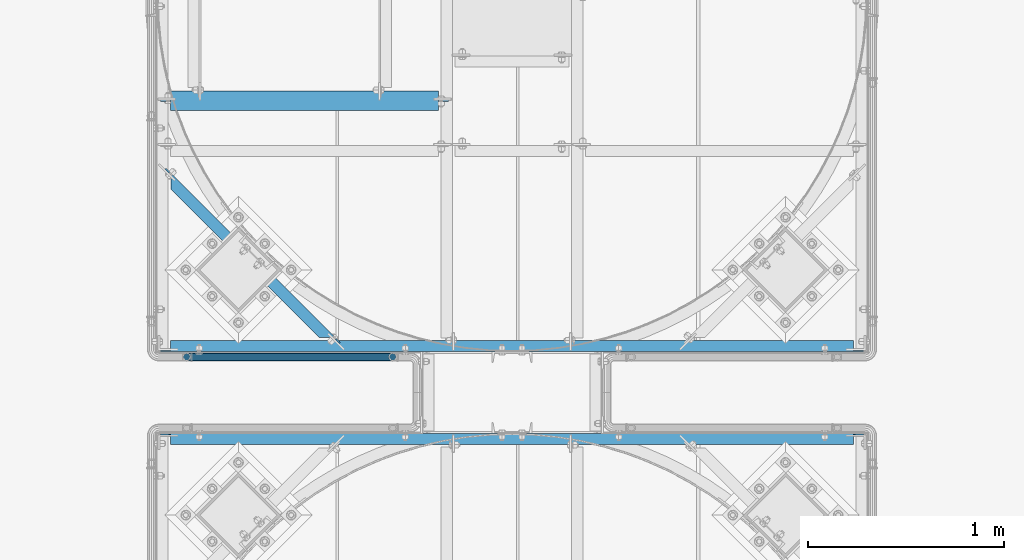
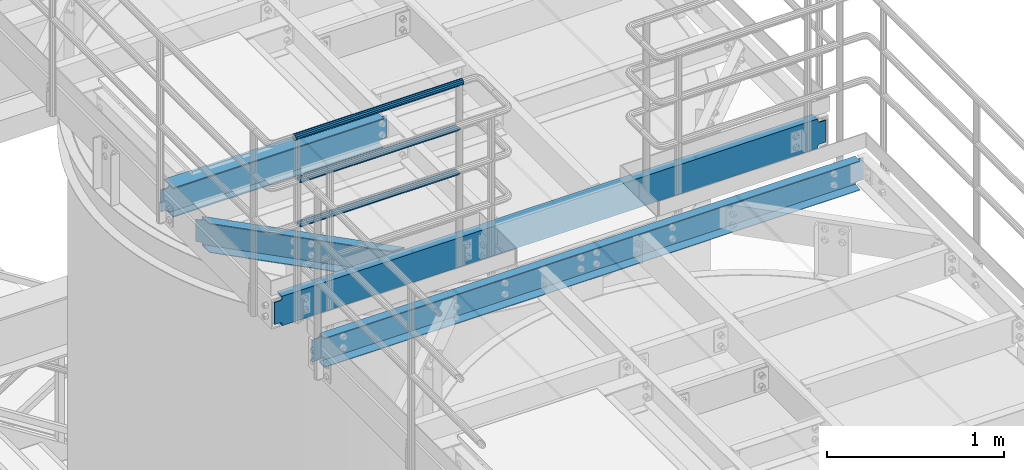
# One storey, part 926 of 1876: 7 beams, 5 elements without a shape of their own.
"""IFC2X3 building model written with IfcOpenShell, lengths in millimetres."""

from ifc_helpers import new_model, si_unit, frame, origin_with_axes, place, context, subcontext, project, spatial, faceted_brep, material, type_object, element, aggregate, save


model = new_model("IFC2X3")

# Units and contexts
model_context = context("Model", 3, precision=1e-05, world=origin_with_axes())
body_context = subcontext(model_context, "Body", "Model", "MODEL_VIEW")
ifc_project = project(units=[si_unit("LENGTHUNIT", "METRE", prefix="MILLI"), si_unit("AREAUNIT", "SQUARE_METRE"), si_unit("VOLUMEUNIT", "CUBIC_METRE"), si_unit("MASSUNIT", "GRAM", prefix="KILO"), si_unit("TIMEUNIT", "SECOND"), si_unit("PLANEANGLEUNIT", "RADIAN"), si_unit("SOLIDANGLEUNIT", "STERADIAN"), si_unit("THERMODYNAMICTEMPERATUREUNIT", "DEGREE_CELSIUS"), si_unit("LUMINOUSINTENSITYUNIT", "LUMEN")], contexts=[model_context])

# Site, building, storey
site_placement = place(None, origin_with_axes())
site = spatial("IfcSite", under=ifc_project, at=site_placement, CompositionType="ELEMENT")
building_placement = place(site_placement, origin_with_axes())
building = spatial("IfcBuilding", under=site, at=building_placement, Name="Undefined", CompositionType="ELEMENT")
storey_placement = place(building_placement, origin_with_axes())
storey = spatial("IfcBuildingStorey", under=building, at=storey_placement, Name="Undefined", CompositionType="ELEMENT", Elevation=0.0)

# Assembly, beams
assembly_1_placement = place(storey_placement, origin_with_axes())
assembly_1 = element("IfcElementAssembly", 1, at=assembly_1_placement, inside=storey, Name="HANDRAIL", AssemblyPlace="NOTDEFINED", PredefinedType="RIGID_FRAME")
ifc_material_1 = material()
beam_type_1 = type_object("IfcBeamType", Name="PIPE1-1/4STD", PredefinedType="NOTDEFINED")
beam_1_placement = place(assembly_1_placement, frame((4572.00474593762, -11381.1963554687, 8480.425), z_axis=(0.0, 0.0, 1.0), x_axis=(-1.0, 0.0, 0.0)))
beam_1 = element("IfcBeam", 2, at=beam_1_placement, type_object=beam_type_1, material=ifc_material_1, Name="RAIL", ObjectType="PIPE1-1/4STD", context=body_context, shape_type="Brep", body=[
    faceted_brep([(1035.84245243742, -10.5409999999993, 18.2575475625836), (1035.84245243742, -10.5409999999993, 13.3999612267253), (1035.36603877327, -8.76300000000083, 15.1779612267255), (1033.018, 0.0, 17.5259999999998), (1033.018, 0.0, 21.0820000000003), (1035.36603877327, 8.76300000000083, 15.1779612267255), (1035.84245243742, 10.5409999999993, 13.3999612267253), (1035.84245243742, 10.5409999999993, 18.2575475625836), (1054.1, 21.0820000000003, 0.0), (1043.559, 18.2575475625836, 10.5409999999993), (1043.559, 18.2575475625836, -10.5409999999993), (1040.47941366414, 15.1779612267255, 8.76300000000083), (1042.82745243742, 17.5259999999998, 0.0), (1040.47941366414, 15.1779612267255, -8.76300000000083), (1035.84245243742, 10.5409999999993, -13.3999612267253), (1035.84245243742, 10.5409999999993, -18.2575475625836), (1035.36603877327, 8.76300000000083, -15.1779612267255), (1033.018, 0.0, -17.5259999999998), (1033.018, 0.0, -21.0820000000003), (1035.84245243742, -10.5409999999993, -13.3999612267253), (1035.84245243742, -10.5409999999993, -18.2575475625836), (1035.36603877327, -8.76300000000083, -15.1779612267255), (1054.1, -21.0820000000003, 0.0), (1043.559, -18.2575475625836, -10.5409999999993), (1043.559, -18.2575475625836, 10.5409999999993), (1040.47941366414, -15.1779612267255, -8.76300000000083), (1042.82745243742, -17.5259999999998, 0.0), (1040.47941366414, -15.1779612267255, 8.76300000000083), (10.5409999957128, -18.2575475672238, -10.5409999999993), (18.2575475625817, -10.5410000000011, -18.2575475625836), (9.09494701772928e-13, 21.0820000000003, 0.0), (10.5409999957128, 18.2575475579433, -10.5409999999993), (10.5409999999983, 18.2575475625836, 10.5410000000011), (18.2575475625817, 10.5409999999993, 18.2575475625836), (21.0819999999985, 1.81898940354586e-12, 21.0820000000003), (18.2575475625817, 10.5409999999993, -18.2575475625836), (21.0819999999985, 0.0, -21.0819999999985), (21.0819999999985, 0.0, -17.5259999999998), (18.2575475625817, -10.5409999999974, -13.3999612267271), (18.7339612267233, -8.76300000000083, -15.1779612267255), (18.7339612267251, 8.76299999999901, -15.1779612267255), (18.2575475625817, 10.5410000000011, -13.3999612267235), (13.6205863358573, 15.1779612267255, -8.76299999999901), (11.2725475625839, 17.5259999999998, 0.0), (13.6205863358573, 15.1779612267255, 8.76300000000083), (18.2575475625817, 10.5410000000011, 13.3999612267253), (18.7339612267251, 8.76299999999901, 15.1779612267273), (21.0819999999985, 1.81898940354586e-12, 17.5259999999998), (18.7339612267233, -8.76300000000083, 15.1779612267273), (18.2575475625817, -10.5409999999974, 13.3999612267289), (18.2575475625817, -10.5410000000011, 18.2575475625836), (10.5409999999983, -18.2575475625836, 10.5410000000011), (9.09494701772928e-13, -21.0820000000003, 0.0), (13.6205863358537, -15.1779612267255, 8.76300000000083), (11.2725475625793, -17.5259999999998, 0.0), (13.6205863358537, -15.1779612267255, -8.76299999999901)], [[[0, 1, 2, 3, 4]], [[4, 3, 5, 6, 7]], [[8, 9, 10]], [[7, 6, 11, 12, 13, 14, 15, 10, 9]], [[16, 17, 18, 15, 14]], [[19, 20, 18, 17, 21]], [[22, 23, 24]], [[24, 23, 20, 19, 25, 26, 27, 1, 0]], [[28, 29, 20, 23]], [[30, 31, 32]], [[33, 34, 4, 7]], [[32, 33, 7, 9]], [[30, 32, 9, 8]], [[31, 30, 8, 10]], [[35, 31, 10, 15]], [[36, 35, 15, 18]], [[29, 36, 18, 20]], [[37, 36, 29, 38, 39]], [[40, 41, 35, 36, 37]], [[32, 31, 35, 41, 42, 43, 44, 45, 33]], [[33, 45, 46, 47, 34]], [[34, 47, 48, 49, 50]], [[34, 50, 0, 4]], [[50, 51, 24, 0]], [[51, 52, 22, 24]], [[52, 28, 23, 22]], [[51, 28, 52]], [[50, 49, 53, 54, 55, 38, 29, 28, 51]], [[55, 54, 26, 25]], [[21, 39, 38, 55, 25, 19]], [[37, 39, 21, 17]], [[40, 37, 17, 16]], [[42, 41, 40, 16, 14, 13]], [[43, 42, 13, 12]], [[44, 43, 12, 11]], [[5, 46, 45, 44, 11, 6]], [[47, 46, 5, 3]], [[48, 47, 3, 2]], [[53, 49, 48, 2, 1, 27]], [[54, 53, 27, 26]]]),
])
beam_2_placement = place(assembly_1_placement, frame((3517.90474593762, -11381.1963554687, 8785.225), z_axis=(0.0, 0.0, -1.0), x_axis=(1.0, 0.0, 0.0)))
beam_2 = element("IfcBeam", 3, at=beam_2_placement, type_object=beam_type_1, material=ifc_material_1, Name="RAIL", ObjectType="PIPE1-1/4STD", context=body_context, shape_type="Brep", body=[
    faceted_brep([(9.09494701772928e-13, 21.0820000000003, 0.0), (10.5409999957128, 18.2575475579433, -10.5409999999993), (10.5409999999983, 18.2575475625836, 10.5410000000011), (10.5409999999983, -18.2575475625836, 10.5410000000011), (10.5409999957128, -18.2575475672238, -10.5409999999993), (9.09494701772928e-13, -21.0820000000003, 0.0), (18.2575475625817, -10.5410000000011, 18.2575475625836), (18.2575475625817, -10.5409999999974, 13.3999612267289), (13.6205863358537, -15.1779612267255, 8.76300000000083), (11.2725475625793, -17.5259999999998, 0.0), (13.6205863358537, -15.1779612267255, -8.76299999999901), (18.2575475625817, -10.5409999999974, -13.3999612267271), (18.2575475625817, -10.5410000000011, -18.2575475625836), (21.0819999999985, 0.0, -17.5259999999998), (21.0819999999985, 0.0, -21.0819999999985), (18.7339612267233, -8.76300000000083, -15.1779612267255), (18.7339612267251, 8.76299999999901, -15.1779612267255), (18.2575475625817, 10.5410000000011, -13.3999612267235), (18.2575475625817, 10.5409999999993, -18.2575475625836), (13.6205863358573, 15.1779612267255, -8.76299999999901), (11.2725475625839, 17.5259999999998, 0.0), (13.6205863358573, 15.1779612267255, 8.76300000000083), (18.2575475625817, 10.5410000000011, 13.3999612267253), (18.2575475625817, 10.5409999999993, 18.2575475625836), (18.7339612267251, 8.76299999999901, 15.1779612267273), (21.0819999999985, 1.81898940354586e-12, 17.5259999999998), (21.0819999999985, 1.81898940354586e-12, 21.0820000000003), (18.7339612267233, -8.76300000000083, 15.1779612267273), (1054.1, 21.0820000000003, 0.0), (1043.559, 18.2575475625836, -10.5409999999993), (1035.84245243742, 10.5409999999993, -18.2575475625836), (1054.1, -21.0820000000003, 0.0), (1043.559, -18.2575475625836, -10.5409999999993), (1043.559, -18.2575475625836, 10.5409999999993), (1035.84245243742, -10.5409999999993, 18.2575475625836), (1035.84245243742, -10.5409999999993, -18.2575475625836), (1033.018, 0.0, -21.0820000000003), (1035.36603877327, 8.76300000000083, -15.1779612267255), (1033.018, 0.0, -17.5259999999998), (1035.84245243742, 10.5409999999993, -13.3999612267253), (1035.84245243742, -10.5409999999993, -13.3999612267253), (1035.36603877327, -8.76300000000083, -15.1779612267255), (1040.47941366414, -15.1779612267255, -8.76300000000083), (1042.82745243742, -17.5259999999998, 0.0), (1040.47941366414, -15.1779612267255, 8.76300000000083), (1035.84245243742, -10.5409999999993, 13.3999612267253), (1035.36603877327, -8.76300000000083, 15.1779612267255), (1033.018, 0.0, 17.5259999999998), (1033.018, 0.0, 21.0820000000003), (1035.84245243742, 10.5409999999993, 18.2575475625836), (1043.559, 18.2575475625836, 10.5409999999993), (1035.84245243742, 10.5409999999993, 13.3999612267253), (1040.47941366414, 15.1779612267255, 8.76300000000083), (1042.82745243742, 17.5259999999998, 0.0), (1040.47941366414, 15.1779612267255, -8.76300000000083), (1035.36603877327, 8.76300000000083, 15.1779612267255)], [[[0, 1, 2]], [[3, 4, 5]], [[6, 7, 8, 9, 10, 11, 12, 4, 3]], [[13, 14, 12, 11, 15]], [[16, 17, 18, 14, 13]], [[2, 1, 18, 17, 19, 20, 21, 22, 23]], [[23, 22, 24, 25, 26]], [[26, 25, 27, 7, 6]], [[1, 0, 28, 29]], [[18, 1, 29, 30]], [[31, 32, 33]], [[6, 3, 33, 34]], [[3, 5, 31, 33]], [[5, 4, 32, 31]], [[4, 12, 35, 32]], [[12, 14, 36, 35]], [[14, 18, 30, 36]], [[37, 38, 36, 30, 39]], [[40, 35, 36, 38, 41]], [[33, 32, 35, 40, 42, 43, 44, 45, 34]], [[34, 45, 46, 47, 48]], [[26, 6, 34, 48]], [[2, 23, 49, 50]], [[23, 26, 48, 49]], [[0, 2, 50, 28]], [[28, 50, 29]], [[49, 51, 52, 53, 54, 39, 30, 29, 50]], [[48, 47, 55, 51, 49]], [[25, 24, 55, 47]], [[55, 24, 22, 21, 52, 51]], [[21, 20, 53, 52]], [[20, 19, 54, 53]], [[19, 17, 16, 37, 39, 54]], [[16, 13, 38, 37]], [[13, 15, 41, 38]], [[41, 15, 11, 10, 42, 40]], [[10, 9, 43, 42]], [[9, 8, 44, 43]], [[8, 7, 27, 46, 45, 44]], [[27, 25, 47, 46]]]),
])
beam_3_placement = place(assembly_1_placement, frame((3496.82274593762, -11381.1963554687, 9090.025), z_axis=(0.0, 0.0, -1.0), x_axis=(1.0, 0.0, 0.0)))
beam_3 = element("IfcBeam", 4, at=beam_3_placement, type_object=beam_type_1, material=ifc_material_1, Name="HANDRAIL", ObjectType="PIPE1-1/4STD", context=body_context, shape_type="Brep", body=[
    faceted_brep([(0.0, -17.5259999999998, 0.0), (0.0, -15.1779612267264, 8.76300000000083), (1096.264, -15.1779612267255, 8.76300000000083), (1096.264, -17.5259999999998, 0.0), (0.0, -8.76299999999992, 15.1779612267255), (1096.264, -8.76300000000083, 15.1779612267255), (0.0, 0.0, 17.5259999999998), (1096.264, 0.0, 17.5259999999998), (0.0, 8.76299999999992, 15.1779612267255), (1096.264, 8.76300000000083, 15.1779612267255), (0.0, 15.1779612267264, 8.76300000000083), (1096.264, 15.1779612267255, 8.76300000000083), (0.0, 17.5259999999998, 0.0), (1096.264, 17.5259999999998, 0.0), (0.0, 15.1779612267264, -8.76300000000083), (1096.264, 15.1779612267255, -8.76300000000083), (0.0, 8.76299999999992, -15.1779612267255), (1096.264, 8.76300000000083, -15.1779612267255), (0.0, 0.0, -17.5259999999998), (1096.264, 0.0, -17.5259999999998), (0.0, -8.76299999999992, -15.1779612267255), (1096.264, -8.76300000000083, -15.1779612267255), (0.0, -15.1779612267264, -8.76300000000083), (1096.264, -15.1779612267255, -8.76300000000083), (9.09494701772928e-13, -21.0820000000003, 0.0), (0.0, -18.2575475625836, -10.5409999999993), (1096.264, -18.2575475625836, -10.5409999999993), (1096.264, -21.0820000000003, 0.0), (0.0, -10.5410000000002, -18.2575475625836), (1096.264, -10.5409999999993, -18.2575475625836), (-4.28826751885936e-09, 0.0, -21.0820000000003), (1096.264, 0.0, -21.0820000000003), (0.0, 10.5410000000002, -18.2575475625836), (1096.264, 10.5409999999993, -18.2575475625836), (0.0, 18.2575475625836, -10.5409999999993), (1096.264, 18.2575475625836, -10.5409999999993), (9.09494701772928e-13, 21.0820000000003, 0.0), (1096.264, 21.0820000000003, 0.0), (0.0, 18.2575475625836, 10.5409999999993), (1096.264, 18.2575475625836, 10.5409999999993), (0.0, 10.5410000000002, 18.2575475625836), (1096.264, 10.5409999999993, 18.2575475625836), (0.0, 0.0, 21.0820000000003), (1096.264, 0.0, 21.0820000000003), (0.0, -10.5410000000002, 18.2575475625836), (1096.264, -10.5409999999993, 18.2575475625836), (0.0, -18.2575475625836, 10.5409999999993), (1096.264, -18.2575475625836, 10.5409999999993)], [[[0, 1, 2, 3]], [[1, 4, 5, 2]], [[4, 6, 7, 5]], [[6, 8, 9, 7]], [[8, 10, 11, 9]], [[10, 12, 13, 11]], [[12, 14, 15, 13]], [[14, 16, 17, 15]], [[16, 18, 19, 17]], [[18, 20, 21, 19]], [[20, 22, 23, 21]], [[22, 0, 3, 23]], [[24, 25, 26, 27]], [[25, 28, 29, 26]], [[28, 30, 31, 29]], [[30, 32, 33, 31]], [[32, 34, 35, 33]], [[34, 36, 37, 35]], [[36, 38, 39, 37]], [[38, 40, 41, 39]], [[40, 42, 43, 41]], [[42, 44, 45, 43]], [[44, 46, 47, 45]], [[46, 24, 27, 47]], [[29, 31, 33, 35, 37, 39, 41, 43, 45, 47, 27, 26], [5, 7, 9, 11, 13, 15, 17, 19, 21, 23, 3, 2]], [[46, 44, 42, 40, 38, 36, 34, 32, 30, 28, 25, 24], [22, 20, 18, 16, 14, 12, 10, 8, 6, 4, 1, 0]]]),
])
aggregate(assembly_1, [beam_1, beam_2, beam_3])

# Assembly, beam
assembly_2_placement = place(storey_placement, origin_with_axes())
assembly_2 = element("IfcElementAssembly", 5, at=assembly_2_placement, inside=storey, Name="BEAM", AssemblyPlace="NOTDEFINED", PredefinedType="RIGID_FRAME")
ifc_material_2 = material(Name="STEEL/A36")
beam_type_2 = type_object("IfcBeamType", Name="C8X11.5", PredefinedType="NOTDEFINED")
beam_4_placement = place(assembly_2_placement, frame((3349.46494957745, -10395.0777447411, 7896.225), z_axis=(0.0, 0.0, 1.0), x_axis=(0.707106781186547, -0.707106781186548, 0.0)))
beam_4 = element("IfcBeam", 6, at=beam_4_placement, type_object=beam_type_2, material=ifc_material_2, Name="BEAM", ObjectType="C8X11.5", context=body_context, shape_type="Brep", body=[
    faceted_brep([(154.529650862243, -28.5750000000025, 101.6), (154.529650862243, -28.5750000000025, 96.8355949999996), (1223.93966372519, -28.5750000000044, 96.8355949999996), (1223.93966372519, -28.5750000000044, 101.6), (92.6423292584636, 22.225000000004, 77.1667299225874), (86.2923292584624, 28.5750000000062, 77.1667299225874), (79.4191388898289, 28.5750000000062, 76.1999999999998), (85.7691388898302, 22.225000000004, 76.1999999999998), (98.4691386990994, 22.225000000004, 79.9197438230658), (92.119138699099, 28.5750000000062, 79.9197438230658), (102.362488294559, 22.225000000004, 84.0399202912195), (96.0124882945579, 28.5750000000062, 84.0399202912195), (106.897026668147, 19.0576241940926, 88.899999809265), (97.3796508622331, 28.5750000000062, 88.899999809265), (103.581210715098, 22.225000000004, 88.3723149999996), (1274.88810387234, 22.2250000000049, 88.3723149999996), (1271.57228791927, 19.0576241940789, 88.8999998092668), (97.3796508622331, 28.5750000000062, 101.6), (1292.70017569896, 22.225000000004, -76.1999999999971), (1299.05017569896, 28.5750000000053, -76.1999999999971), (1319.3218385947, 28.5750000000053, -76.1999999999971), (1319.3218385947, 22.225000000004, -76.1999999999971), (1285.82698533033, 22.2250000000049, -77.1667299225846), (1292.17698533033, 28.5750000000062, -77.1667299225846), (1280.00017588969, 22.2250000000049, -79.9197438230631), (1286.35017588969, 28.5750000000062, -79.9197438230631), (1276.10682629423, 22.2250000000031, -84.0399202912167), (1282.45682629424, 28.5750000000044, -84.0399202912167), (1274.88810387369, 22.225000000004, -88.3723149999996), (1271.57228792066, 19.0576241941089, -88.8999998092622), (1281.08966372656, 28.5750000000062, -88.8999998092622), (103.581210715046, 22.225000000004, -88.3723149999996), (106.897026668097, 19.0576241940926, -88.899999809265), (154.529650862193, -28.5750000000044, -96.8355949999996), (1223.93966372655, -28.5750000000035, -96.8355949999996), (154.529650862193, -28.5750000000044, -101.6), (1223.93966372655, -28.5750000000035, -101.6), (1281.08966372656, 28.5750000000062, -101.6), (97.3796508621845, 28.5750000000044, -101.6), (97.3796508621845, 28.5750000000044, -88.899999809265), (102.362488294509, 22.225000000004, -84.0399202912195), (96.0124882945074, 28.5750000000062, -84.0399202912195), (98.4691386990489, 22.2250000000058, -79.9197438230658), (92.1191386990495, 28.5750000000044, -79.9197438230658), (92.6423292584141, 22.225000000004, -77.1667299225874), (86.2923292584137, 28.5750000000044, -77.1667299225874), (85.7691388897797, 22.225000000004, -76.1999999999998), (79.4191388897784, 28.5750000000062, -76.1999999999998), (59.1474759898592, 22.225000000004, -76.1999999999998), (59.1474759898588, 28.5750000000062, -76.1999999999998), (1281.0896637252, 28.5750000000053, 101.6), (1281.0896637252, 28.5750000000053, 88.8999998092668), (1282.45682629288, 28.5750000000044, 84.0399202912213), (1286.35017588834, 28.5750000000053, 79.9197438230676), (1292.17698532897, 28.5750000000053, 77.1667299225892), (1299.0501756976, 28.5750000000053, 76.2000000000016), (1319.3218385947, 28.5750000000053, 76.2000000000016), (59.1474759898588, 28.5750000000062, 76.1999999999998), (59.1474759898592, 22.225000000004, 76.1999999999998), (1319.3218385947, 22.225000000004, 76.2000000000016), (1292.7001756976, 22.2250000000049, 76.2000000000016), (1285.82698532897, 22.225000000004, 77.1667299225892), (1280.00017588834, 22.225000000004, 79.9197438230676), (1276.10682629288, 22.225000000004, 84.0399202912213)], [[[0, 1, 2, 3]], [[4, 5, 6, 7]], [[8, 9, 5, 4]], [[10, 11, 9, 8]], [[12, 13, 11, 10, 14]], [[2, 1, 12, 14, 15, 16]], [[0, 17, 13, 12, 1]], [[18, 19, 20, 21]], [[19, 18, 22, 23]], [[23, 22, 24, 25]], [[25, 24, 26, 27]], [[27, 26, 28, 29, 30]], [[31, 32, 33, 34, 29, 28]], [[33, 35, 36, 34]], [[30, 29, 34, 36, 37]], [[35, 38, 37, 36]], [[33, 32, 39, 38, 35]], [[31, 40, 41, 39, 32]], [[42, 43, 41, 40]], [[44, 45, 43, 42]], [[46, 47, 45, 44]], [[47, 46, 48, 49]], [[6, 5, 9, 11, 13, 17, 50, 51, 52, 53, 54, 55, 56, 20, 19, 23, 25, 27, 30, 37, 38, 39, 41, 43, 45, 47, 49, 57]], [[7, 6, 57, 58]], [[49, 48, 58, 57]], [[46, 44, 42, 40, 31, 28, 26, 24, 22, 18, 21, 59, 60, 61, 62, 63, 15, 14, 10, 8, 4, 7, 58, 48]], [[20, 56, 59, 21]], [[55, 60, 59, 56]], [[54, 61, 60, 55]], [[53, 62, 61, 54]], [[52, 63, 62, 53]], [[51, 16, 15, 63, 52]], [[50, 3, 2, 16, 51]], [[17, 0, 3, 50]]]),
])
aggregate(assembly_2, [beam_4])

assembly_3_placement = place(storey_placement, origin_with_axes())
assembly_3 = element("IfcElementAssembly", 7, at=assembly_3_placement, inside=storey, Name="BEAM", AssemblyPlace="NOTDEFINED", PredefinedType="RIGID_FRAME")
beam_5_placement = place(assembly_3_placement, frame((3365.50333884985, -11325.1893554687, 7896.225), z_axis=(0.0, 0.0, -1.0), x_axis=(1.0, 0.0, 0.0)))
beam_5 = element("IfcBeam", 8, at=beam_5_placement, type_object=beam_type_2, material=ifc_material_2, Name="BEAM", ObjectType="C8X11.5", context=body_context, shape_type="Brep", body=[
    faceted_brep([(3562.34713699756, -28.5749999999998, -96.8355949999996), (3562.34713699756, -28.5749999999998, -101.6), (3562.34713699756, 28.5749999999998, -101.6), (3562.34713699756, 28.5749999999998, -88.8999998092659), (3562.34713699756, 19.0576241940826, -88.8999998092659), (3562.45210003221, 22.2250000000004, -88.3723149999996), (3563.31386692015, 28.5749999999998, -84.0399202912204), (3563.31386692015, 22.2250000000004, -84.0399202912204), (3566.06688082063, 28.5749999999998, -79.9197438230667), (3566.06688082063, 22.2250000000004, -79.9197438230667), (3570.18705728878, 28.5749999999998, -77.1667299225883), (3570.18705728878, 22.2250000000004, -77.1667299225883), (3575.04713680683, 28.5749999999998, -76.2000000000007), (3575.04713680683, 22.2250000000004, -76.2000000000007), (3613.14713699757, 22.2250000000004, -76.2000000000007), (3613.14713699757, 28.5749999999998, -76.2000000000007), (69.8500000000013, 28.5750000000007, 101.6), (69.8500000000013, -28.5750000000007, 101.6), (3562.34713699756, -28.5749999999998, 101.6), (3562.34713699756, 28.5749999999998, 101.6), (69.8500000000013, 19.0576241940817, -88.8999998092659), (69.8500000000013, 28.5750000000007, -88.8999998092659), (69.8500000000013, 28.5750000000007, -101.6), (69.8500000000013, -28.5750000000007, -101.6), (69.8500000000013, -28.5750000000007, -96.8355949999996), (69.7450369653598, 22.2250000000004, -88.3723149999996), (68.8832700774137, 22.2250000000004, -84.0399202912204), (68.8832700774137, 28.5750000000007, -84.0399202912204), (66.1302561769353, 22.2250000000004, -79.9197438230667), (66.1302561769353, 28.5750000000007, -79.9197438230667), (62.0100797087816, 22.2250000000004, -77.1667299225883), (62.0100797087816, 28.5750000000007, -77.1667299225883), (57.1500001907361, 22.2250000000004, -76.2000000000007), (57.1500001907361, 28.5750000000007, -76.2000000000007), (19.0499999999993, 22.2250000000004, -76.2000000000007), (19.0499999999993, 28.5750000000007, -76.2000000000007), (19.0499999999993, 22.2250000000004, 76.1999999999989), (19.0499999999993, 28.5750000000007, 76.1999999999989), (57.1500001907361, 22.2250000000004, 76.1999999999989), (57.1500001907361, 28.5750000000007, 76.1999999999989), (62.0100797087816, 22.2250000000004, 77.1667299225865), (62.0100797087816, 28.5750000000007, 77.1667299225865), (66.1302561769353, 22.2250000000004, 79.9197438230649), (66.1302561769353, 28.5750000000007, 79.9197438230649), (68.8832700774137, 22.2250000000004, 84.0399202912186), (68.8832700774137, 28.5750000000007, 84.0399202912186), (69.8500000000013, 19.0576241940926, 88.899999809264), (69.8500000000013, 28.5750000000007, 88.899999809264), (69.7450369653607, 22.2250000000004, 88.3723149999996), (69.8500000000013, -28.5750000000007, 96.8355949999996), (3562.34713699756, -28.5749999999998, 96.8355949999996), (3562.34713699756, 19.0576241940935, 88.899999809264), (3562.34713699756, 28.5749999999998, 88.899999809264), (3562.4521000322, 22.2250000000004, 88.3723149999996), (3563.31386692015, 22.2250000000004, 84.0399202912186), (3563.31386692015, 28.5749999999998, 84.0399202912186), (3566.06688082063, 22.2250000000004, 79.9197438230649), (3566.06688082063, 28.5749999999998, 79.9197438230649), (3570.18705728878, 22.2250000000004, 77.1667299225865), (3570.18705728878, 28.5749999999998, 77.1667299225865), (3575.04713680683, 22.2250000000004, 76.1999999999989), (3575.04713680683, 28.5749999999998, 76.1999999999989), (3613.14713699757, 22.2250000000004, 76.1999999999989), (3613.14713699757, 28.5749999999998, 76.1999999999989)], [[[0, 1, 2, 3, 4]], [[5, 4, 3, 6, 7]], [[7, 6, 8, 9]], [[9, 8, 10, 11]], [[11, 10, 12, 13]], [[14, 13, 12, 15]], [[16, 17, 18, 19]], [[20, 21, 22, 23, 24]], [[25, 26, 27, 21, 20]], [[28, 29, 27, 26]], [[30, 31, 29, 28]], [[32, 33, 31, 30]], [[34, 35, 33, 32]], [[36, 37, 35, 34]], [[38, 39, 37, 36]], [[40, 41, 39, 38]], [[42, 43, 41, 40]], [[44, 45, 43, 42]], [[46, 47, 45, 44, 48]], [[17, 16, 47, 46, 49]], [[17, 49, 50, 18]], [[18, 50, 51, 52, 19]], [[49, 46, 48, 53, 51, 50]], [[54, 55, 52, 51, 53]], [[56, 57, 55, 54]], [[58, 59, 57, 56]], [[60, 61, 59, 58]], [[62, 63, 61, 60]], [[63, 62, 14, 15]], [[10, 8, 6, 3, 2, 22, 21, 27, 29, 31, 33, 35, 37, 39, 41, 43, 45, 47, 16, 19, 52, 55, 57, 59, 61, 63, 15, 12]], [[23, 22, 2, 1]], [[24, 23, 1, 0]], [[25, 20, 24, 0, 4, 5]], [[62, 60, 58, 56, 54, 53, 48, 44, 42, 40, 38, 36, 34, 32, 30, 28, 26, 25, 5, 7, 9, 11, 13, 14]]]),
])
aggregate(assembly_3, [beam_5])

assembly_4_placement = place(storey_placement, origin_with_axes())
assembly_4 = element("IfcElementAssembly", 9, at=assembly_4_placement, inside=storey, Name="BEAM", AssemblyPlace="NOTDEFINED", PredefinedType="RIGID_FRAME")
beam_6_placement = place(assembly_4_placement, frame((3365.50143150122, -11801.4394531238, 7896.225), z_axis=(0.0, 0.0, 1.0), x_axis=(1.0, 0.0, 0.0)))
beam_6 = element("IfcBeam", 10, at=beam_6_placement, type_object=beam_type_2, material=ifc_material_2, Name="BEAM", ObjectType="C8X11.5", context=body_context, shape_type="Brep", body=[
    faceted_brep([(3562.34713699756, -28.5749999999998, -96.8355949999996), (3562.34713699756, -28.5749999999998, -101.6), (3562.34713699756, 28.5749999999998, -101.6), (3562.34713699756, 28.5749999999998, -88.8999998092659), (3562.34713699756, 19.0576241940826, -88.8999998092659), (3562.45210003221, 22.2250000000004, -88.3723149999996), (3563.31386692015, 28.5749999999998, -84.0399202912204), (3563.31386692015, 22.2250000000004, -84.0399202912204), (3566.06688082063, 28.5749999999998, -79.9197438230667), (3566.06688082063, 22.2250000000004, -79.9197438230667), (3570.18705728878, 28.5749999999998, -77.1667299225883), (3570.18705728878, 22.2250000000004, -77.1667299225883), (3575.04713680683, 28.5749999999998, -76.2000000000007), (3575.04713680683, 22.2250000000004, -76.2000000000007), (3613.14713699757, 22.2250000000004, -76.2000000000007), (3613.14713699757, 28.5749999999998, -76.2000000000007), (69.8500000000013, 28.5750000000007, 101.6), (69.8500000000013, -28.5750000000007, 101.6), (3562.34713699756, -28.5749999999998, 101.6), (3562.34713699756, 28.5749999999998, 101.6), (69.8500000000013, 19.0576241940817, -88.8999998092659), (69.8500000000013, 28.5750000000007, -88.8999998092659), (69.8500000000013, 28.5750000000007, -101.6), (69.8500000000013, -28.5750000000007, -101.6), (69.8500000000013, -28.5750000000007, -96.8355949999996), (69.7450369653598, 22.2250000000004, -88.3723149999996), (68.8832700774137, 22.2250000000004, -84.0399202912204), (68.8832700774137, 28.5750000000007, -84.0399202912204), (66.1302561769353, 22.2250000000004, -79.9197438230667), (66.1302561769353, 28.5750000000007, -79.9197438230667), (62.0100797087816, 22.2250000000004, -77.1667299225883), (62.0100797087816, 28.5750000000007, -77.1667299225883), (57.1500001907361, 22.2250000000004, -76.2000000000007), (57.1500001907361, 28.5750000000007, -76.2000000000007), (19.0499999999993, 22.2250000000004, -76.2000000000007), (19.0499999999993, 28.5750000000007, -76.2000000000007), (19.0499999999993, 22.2250000000004, 76.1999999999989), (19.0499999999993, 28.5750000000007, 76.1999999999989), (57.1500001907361, 22.2250000000004, 76.1999999999989), (57.1500001907361, 28.5750000000007, 76.1999999999989), (62.0100797087816, 22.2250000000004, 77.1667299225865), (62.0100797087816, 28.5750000000007, 77.1667299225865), (66.1302561769353, 22.2250000000004, 79.9197438230649), (66.1302561769353, 28.5750000000007, 79.9197438230649), (68.8832700774137, 22.2250000000004, 84.0399202912186), (68.8832700774137, 28.5750000000007, 84.0399202912186), (69.8500000000013, 19.0576241940926, 88.899999809264), (69.8500000000013, 28.5750000000007, 88.899999809264), (69.7450369653607, 22.2250000000004, 88.3723149999996), (69.8500000000013, -28.5750000000007, 96.8355949999996), (3562.34713699756, -28.5749999999998, 96.8355949999996), (3562.34713699756, 19.0576241940935, 88.899999809264), (3562.34713699756, 28.5749999999998, 88.899999809264), (3562.4521000322, 22.2250000000004, 88.3723149999996), (3563.31386692015, 22.2250000000004, 84.0399202912186), (3563.31386692015, 28.5749999999998, 84.0399202912186), (3566.06688082063, 22.2250000000004, 79.9197438230649), (3566.06688082063, 28.5749999999998, 79.9197438230649), (3570.18705728878, 22.2250000000004, 77.1667299225865), (3570.18705728878, 28.5749999999998, 77.1667299225865), (3575.04713680683, 22.2250000000004, 76.1999999999989), (3575.04713680683, 28.5749999999998, 76.1999999999989), (3613.14713699757, 22.2250000000004, 76.1999999999989), (3613.14713699757, 28.5749999999998, 76.1999999999989)], [[[0, 1, 2, 3, 4]], [[5, 4, 3, 6, 7]], [[7, 6, 8, 9]], [[9, 8, 10, 11]], [[11, 10, 12, 13]], [[14, 13, 12, 15]], [[16, 17, 18, 19]], [[20, 21, 22, 23, 24]], [[25, 26, 27, 21, 20]], [[28, 29, 27, 26]], [[30, 31, 29, 28]], [[32, 33, 31, 30]], [[34, 35, 33, 32]], [[36, 37, 35, 34]], [[38, 39, 37, 36]], [[40, 41, 39, 38]], [[42, 43, 41, 40]], [[44, 45, 43, 42]], [[46, 47, 45, 44, 48]], [[17, 16, 47, 46, 49]], [[17, 49, 50, 18]], [[18, 50, 51, 52, 19]], [[49, 46, 48, 53, 51, 50]], [[54, 55, 52, 51, 53]], [[56, 57, 55, 54]], [[58, 59, 57, 56]], [[60, 61, 59, 58]], [[62, 63, 61, 60]], [[63, 62, 14, 15]], [[10, 8, 6, 3, 2, 22, 21, 27, 29, 31, 33, 35, 37, 39, 41, 43, 45, 47, 16, 19, 52, 55, 57, 59, 61, 63, 15, 12]], [[23, 22, 2, 1]], [[24, 23, 1, 0]], [[25, 20, 24, 0, 4, 5]], [[62, 60, 58, 56, 54, 53, 48, 44, 42, 40, 38, 36, 34, 32, 30, 28, 26, 25, 5, 7, 9, 11, 13, 14]]]),
])
aggregate(assembly_4, [beam_6])

assembly_5_placement = place(storey_placement, origin_with_axes())
assembly_5 = element("IfcElementAssembly", 11, at=assembly_5_placement, inside=storey, Name="BEAM", AssemblyPlace="NOTDEFINED", PredefinedType="RIGID_FRAME")
ifc_material_3 = material(Name="STEEL/A992")
beam_type_3 = type_object("IfcBeamType", Name="W8X13", PredefinedType="NOTDEFINED")
beam_7_placement = place(assembly_5_placement, frame((3365.50333884985, -10071.0643554687, 7896.225), z_axis=(0.0, 0.0, 1.0), x_axis=(1.0, 0.0, 0.0)))
beam_7 = element("IfcBeam", 12, at=beam_7_placement, type_object=beam_type_3, material=ifc_material_3, Name="BEAM", ObjectType="W8X13", context=body_context, shape_type="Brep", body=[
    faceted_brep([(1441.45000056773, -3.17499999999927, -95.25), (1441.45000056773, -50.7999999999993, -95.25), (1441.45000056773, -50.7999999999993, -101.6), (1441.45000056773, 50.7999999999993, -101.6), (1441.45000056773, 50.7999999999993, -95.25), (1441.45000056773, 3.17499999999927, -95.25), (1441.45000056773, 3.17499999999927, -89.1599998092661), (1441.45000056773, -3.17499999999927, -89.1599998092661), (1442.41673049032, 3.17499999999927, -84.2999202912206), (1442.41673049032, -3.17499999999927, -84.2999202912206), (1445.1697443908, 3.17499999999927, -80.1797438230669), (1445.1697443908, -3.17499999999927, -80.1797438230669), (1449.28992085895, 3.17499999999927, -77.4267299225885), (1449.28992085895, -3.17499999999927, -77.4267299225885), (1454.150000377, 3.17499999999927, -76.4600000000009), (1454.150000377, -3.17499999999927, -76.4600000000009), (1492.25, -3.17499999999927, -76.4600000000009), (1492.25, 3.17499999999927, -76.4600000000009), (69.8500006943577, 3.17500000000018, 95.25), (69.8500006943577, 50.8000000000002, 95.25), (1441.45000056773, 50.7999999999993, 95.25), (1441.45000056773, 3.17499999999927, 95.25), (69.849999432266, -3.17499999999927, -89.1599998092643), (69.849999432266, 3.17499999999927, -89.1599998092643), (69.849999432266, 3.17499999999927, -95.25), (69.849999432266, 50.7999999999993, -95.25), (69.849999432266, 50.7999999999993, -101.6), (69.849999432266, -50.7999999999993, -101.6), (69.849999432266, -50.7999999999993, -95.25), (69.849999432266, -3.17499999999927, -95.25), (68.883269509678, -3.17499999999927, -84.2999202912188), (68.883269509678, 3.17499999999927, -84.2999202912188), (66.1302556092, -3.17499999999927, -80.1797438230651), (66.1302556092, 3.17499999999927, -80.1797438230651), (62.0100791410464, -3.17499999999927, -77.4267299225867), (62.0100791410464, 3.17499999999927, -77.4267299225867), (57.1499996230009, -3.17499999999927, -76.4599999999991), (57.1499996230009, 3.17499999999927, -76.4599999999991), (19.0499999999997, -3.17499999999927, -76.4599999999991), (19.0499999999997, 3.17499999999927, -76.4599999999991), (19.0499999999997, -3.17499999999927, 75.9400016784675), (19.0499999999997, 3.17499999999927, 75.9400016784675), (57.1499996230009, -3.17499999999927, 75.9400016784675), (57.1499996230009, 3.17499999999927, 75.9400016784675), (62.0100791410464, -3.17499999999927, 76.9067316010551), (62.0100791410464, 3.17499999999927, 76.9067316010551), (66.1302556092, -3.17499999999927, 79.6597455015335), (66.1302556092, 3.17499999999927, 79.6597455015335), (68.883269509678, -3.17499999999927, 83.7799219696872), (68.883269509678, 3.17499999999927, 83.7799219696872), (69.849999432266, -3.17499999999927, 88.6400014877327), (69.849999432266, 3.17499999999927, 88.6400014877327), (69.849999432266, -50.7999999999993, 101.6), (69.849999432266, 50.7999999999993, 101.6), (69.8500006943577, -3.17500000000018, 95.25), (69.8500006943577, -50.8000000000002, 95.25), (1441.45000056773, -3.17499999999927, 95.25), (1441.45000056773, -50.7999999999993, 95.25), (1441.45000056773, -50.7999999999993, 101.6), (1441.45000056773, 50.7999999999993, 101.6), (1441.45000056773, -3.17499999999927, 88.6400014877308), (1441.45000056773, 3.17499999999927, 88.6400014877308), (1442.41673049032, -3.17499999999927, 83.7799219696853), (1442.41673049032, 3.17499999999927, 83.7799219696853), (1445.1697443908, -3.17499999999927, 79.6597455015317), (1445.1697443908, 3.17499999999927, 79.6597455015317), (1449.28992085895, -3.17499999999927, 76.9067316010533), (1449.28992085895, 3.17499999999927, 76.9067316010533), (1454.150000377, -3.17499999999927, 75.9400016784657), (1454.150000377, 3.17499999999927, 75.9400016784657), (1492.25, -3.17499999999927, 75.9400016784657), (1492.25, 3.17499999999927, 75.9400016784657)], [[[0, 1, 2, 3, 4, 5, 6, 7]], [[7, 6, 8, 9]], [[9, 8, 10, 11]], [[11, 10, 12, 13]], [[13, 12, 14, 15]], [[16, 15, 14, 17]], [[18, 19, 20, 21]], [[22, 23, 24, 25, 26, 27, 28, 29]], [[30, 31, 23, 22]], [[32, 33, 31, 30]], [[34, 35, 33, 32]], [[36, 37, 35, 34]], [[38, 39, 37, 36]], [[40, 41, 39, 38]], [[42, 43, 41, 40]], [[44, 45, 43, 42]], [[46, 47, 45, 44]], [[48, 49, 47, 46]], [[50, 51, 49, 48]], [[52, 53, 19, 18, 51, 50, 54, 55]], [[55, 54, 56, 57]], [[52, 55, 57, 58]], [[53, 52, 58, 59]], [[19, 53, 59, 20]], [[58, 57, 56, 60, 61, 21, 20, 59]], [[62, 63, 61, 60]], [[64, 65, 63, 62]], [[66, 67, 65, 64]], [[68, 69, 67, 66]], [[70, 71, 69, 68]], [[71, 70, 16, 17]], [[12, 10, 8, 6, 5, 24, 23, 31, 33, 35, 37, 39, 41, 43, 45, 47, 49, 51, 18, 21, 61, 63, 65, 67, 69, 71, 17, 14]], [[25, 24, 5, 4]], [[26, 25, 4, 3]], [[27, 26, 3, 2]], [[28, 27, 2, 1]], [[29, 28, 1, 0]], [[70, 68, 66, 64, 62, 60, 56, 54, 50, 48, 46, 44, 42, 40, 38, 36, 34, 32, 30, 22, 29, 0, 7, 9, 11, 13, 15, 16]]]),
])
aggregate(assembly_5, [beam_7])

save(model, "model.ifc")
